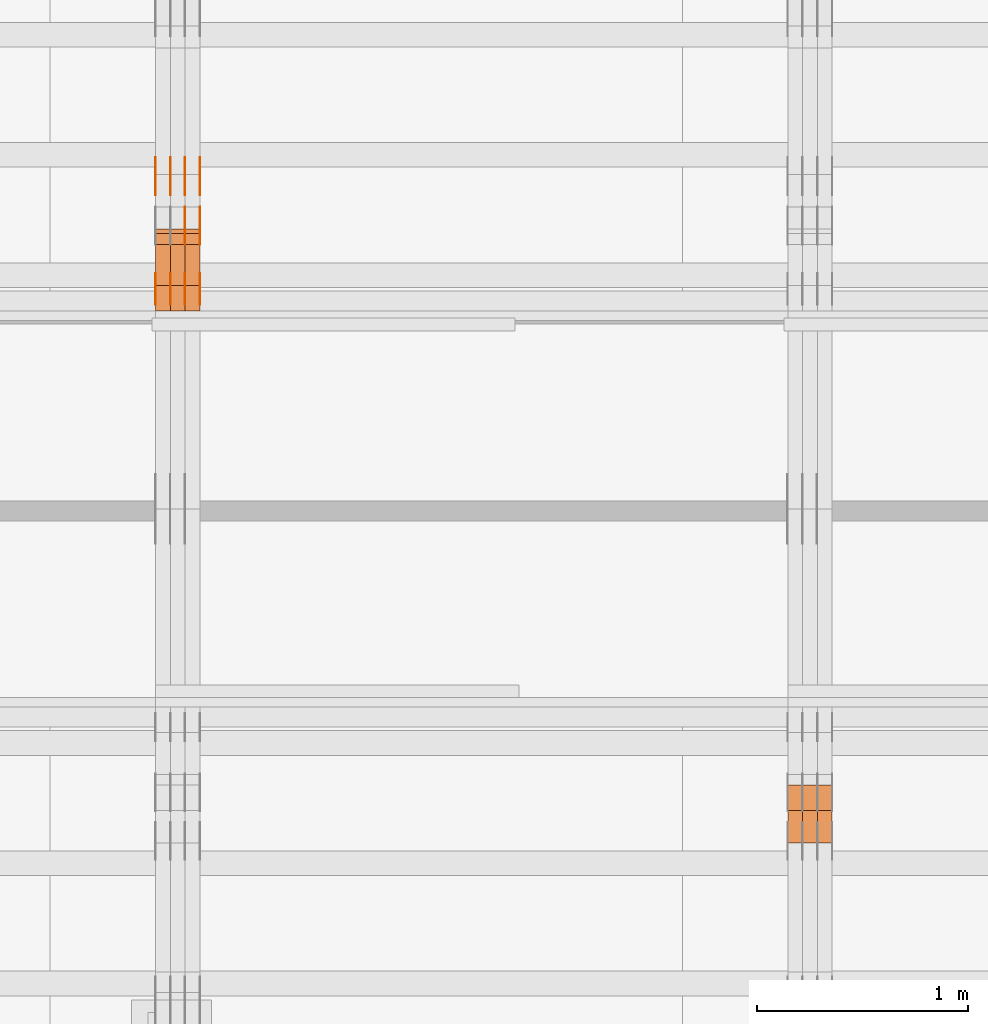
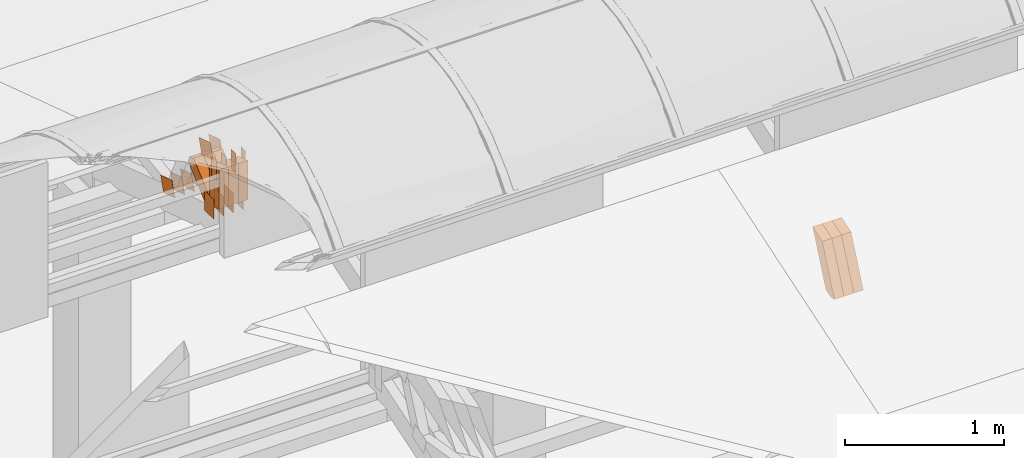
# One storey, part 147 of 385: 30 proxies.
"""IFC2X3 building model written with IfcOpenShell, lengths in millimetres."""

from ifc_helpers import new_model, entity, si_unit, converted_unit, derived_unit, direction, frame, origin, origin_2d_with_axis, place, context, subcontext, project, spatial, polyline, rectangle, outline, extrude, source, transform, mapped, material, type_object, type_shapes, element, save


model = new_model("IFC2X3")

# Units and contexts
model_context = context("Model", 3, precision=0.01, world=origin(), true_north=direction((6.12303176911189e-17, 1.0)))
body_context = subcontext(model_context, "Body", "Model", "MODEL_VIEW")
ifc_project = project(units=[si_unit("LENGTHUNIT", "METRE", prefix="MILLI"), si_unit("AREAUNIT", "SQUARE_METRE"), si_unit("VOLUMEUNIT", "CUBIC_METRE"), converted_unit("PLANEANGLEUNIT", "DEGREE", entity("IfcRatioMeasure", 0.0174532925199433), si_unit("PLANEANGLEUNIT", "RADIAN"), dimensions=[0, 0, 0, 0, 0, 0, 0]), si_unit("MASSUNIT", "GRAM", prefix="KILO"), derived_unit("MASSDENSITYUNIT", [(si_unit("MASSUNIT", "GRAM", prefix="KILO"), 1), (si_unit("LENGTHUNIT", "METRE"), -3)]), si_unit("TIMEUNIT", "SECOND"), si_unit("FREQUENCYUNIT", "HERTZ"), si_unit("THERMODYNAMICTEMPERATUREUNIT", "DEGREE_CELSIUS"), derived_unit("THERMALTRANSMITTANCEUNIT", [(si_unit("MASSUNIT", "GRAM", prefix="KILO"), 1), (si_unit("THERMODYNAMICTEMPERATUREUNIT", "KELVIN"), -1), (si_unit("TIMEUNIT", "SECOND"), -3)]), derived_unit("VOLUMETRICFLOWRATEUNIT", [(si_unit("LENGTHUNIT", "METRE"), 3), (si_unit("TIMEUNIT", "SECOND"), -1)]), si_unit("ELECTRICCURRENTUNIT", "AMPERE"), si_unit("ELECTRICVOLTAGEUNIT", "VOLT"), si_unit("POWERUNIT", "WATT"), si_unit("FORCEUNIT", "NEWTON", prefix="KILO"), si_unit("ILLUMINANCEUNIT", "LUX"), si_unit("LUMINOUSFLUXUNIT", "LUMEN"), si_unit("LUMINOUSINTENSITYUNIT", "CANDELA"), derived_unit("USERDEFINED", [(si_unit("MASSUNIT", "GRAM", prefix="KILO"), -1), (si_unit("LENGTHUNIT", "METRE"), -2), (si_unit("TIMEUNIT", "SECOND"), 3), (si_unit("LUMINOUSFLUXUNIT", "LUMEN"), 1)]), derived_unit("LINEARVELOCITYUNIT", [(si_unit("LENGTHUNIT", "METRE"), 1), (si_unit("TIMEUNIT", "SECOND"), -1)]), si_unit("PRESSUREUNIT", "PASCAL"), derived_unit("USERDEFINED", [(si_unit("LENGTHUNIT", "METRE"), -2), (si_unit("MASSUNIT", "GRAM", prefix="KILO"), 1), (si_unit("TIMEUNIT", "SECOND"), -2)])], contexts=[model_context])

# Site, building, storey
site_placement = place(None, origin())
site = spatial("IfcSite", under=ifc_project, at=site_placement, CompositionType="ELEMENT")
building_placement = place(site_placement, origin())
building = spatial("IfcBuilding", under=site, at=building_placement, CompositionType="ELEMENT")
storey_placement = place(building_placement, origin())
storey = spatial("IfcBuildingStorey", under=building, at=storey_placement, Name="Default", CompositionType="ELEMENT", Elevation=0.0)

# Proxies
ifc_material_1 = material(Name="IfcSurfaceStyle #258636")
building_element_proxy_type_1 = type_object("IfcBuildingElementProxyType", Name="T1-W42 258634", PredefinedType="NOTDEFINED", material=ifc_material_1)
shared_shape_1 = source(origin(), body_context, "Body", "SweptSolid", [
    extrude(outline(polyline([(-284.837590197601, -47.4997543607933), (129.95880168156, -47.4997543607933), (171.972324990451, 0.000162623346093338), (183.717007105413, 47.4996730491203), (-200.810543579822, 47.4996730491203), (-284.837590197601, -47.4997543607933)])), frame((183.717155718752, 47.4999821655365, 0.0), z_axis=(0.0, 0.0, 1.0), x_axis=(-1.0, 0.0, 0.0)), (0.0, 0.0, 1.0), 70.0),
])
type_shapes(building_element_proxy_type_1, [shared_shape_1])
proxy_1_placement = place(building_placement, frame((21385.0, 13135.8834463264, 3404.958483022), z_axis=(-1.0, 0.0, 0.0), x_axis=(0.0, 0.398630596470292, 0.917111578575769)))
element("IfcBuildingElementProxy", 1, at=proxy_1_placement, inside=storey, type_object=building_element_proxy_type_1, material=ifc_material_1, Name="T1-W42", context=body_context, shape_type="MappedRepresentation", body=[
    mapped(shared_shape_1, transform((0.0, 0.0, 0.0), scale=1.0)),
])
ifc_material_2 = material(Name="IfcSurfaceStyle #258570")
building_element_proxy_type_2 = type_object("IfcBuildingElementProxyType", Name="T1-W42 258568", PredefinedType="NOTDEFINED", material=ifc_material_2)
shared_shape_2 = source(origin(), body_context, "Body", "SweptSolid", [
    extrude(outline(polyline([(-284.837590197601, -47.4997543607933), (129.95880168156, -47.4997543607933), (171.972324990451, 0.000162623346093338), (183.717007105413, 47.4996730491203), (-200.810543579822, 47.4996730491203), (-284.837590197601, -47.4997543607933)])), frame((183.717155718752, 47.4999821655365, 0.0), z_axis=(0.0, 0.0, 1.0), x_axis=(-1.0, 0.0, 0.0)), (0.0, 0.0, 1.0), 70.0),
])
type_shapes(building_element_proxy_type_2, [shared_shape_2])
proxy_2_placement = place(building_placement, frame((21315.0, 13135.8834463264, 3404.958483022), z_axis=(-1.0, 0.0, 0.0), x_axis=(0.0, 0.398630596470292, 0.917111578575769)))
element("IfcBuildingElementProxy", 2, at=proxy_2_placement, inside=storey, type_object=building_element_proxy_type_2, material=ifc_material_2, Name="T1-W42", context=body_context, shape_type="MappedRepresentation", body=[
    mapped(shared_shape_2, transform((0.0, 0.0, 0.0), scale=1.0)),
])
ifc_material_3 = material(Name="IfcSurfaceStyle #258504")
building_element_proxy_type_3 = type_object("IfcBuildingElementProxyType", Name="T1-W42 258502", PredefinedType="NOTDEFINED", material=ifc_material_3)
shared_shape_3 = source(origin(), body_context, "Body", "SweptSolid", [
    extrude(outline(polyline([(-284.837590197601, -47.4997543607933), (129.95880168156, -47.4997543607933), (171.972324990451, 0.000162623346093338), (183.717007105413, 47.4996730491203), (-200.810543579822, 47.4996730491203), (-284.837590197601, -47.4997543607933)])), frame((183.717155718752, 47.4999821655365, 0.0), z_axis=(0.0, 0.0, 1.0), x_axis=(-1.0, 0.0, 0.0)), (0.0, 0.0, 1.0), 70.0),
])
type_shapes(building_element_proxy_type_3, [shared_shape_3])
proxy_3_placement = place(building_placement, frame((21245.0, 13135.8834463264, 3404.958483022), z_axis=(-1.0, 0.0, 0.0), x_axis=(0.0, 0.398630596470292, 0.917111578575769)))
element("IfcBuildingElementProxy", 3, at=proxy_3_placement, inside=storey, type_object=building_element_proxy_type_3, material=ifc_material_3, Name="T1-W42", context=body_context, shape_type="MappedRepresentation", body=[
    mapped(shared_shape_3, transform((0.0, 0.0, 0.0), scale=1.0)),
])
ifc_material_4 = material(Name="IfcSurfaceStyle #239810")
building_element_proxy_type_4 = type_object("IfcBuildingElementProxyType", PredefinedType="NOTDEFINED", material=ifc_material_4)
shared_shape_4 = source(origin(), body_context, "Body", "SweptSolid", [
    extrude(rectangle(XDim=150.0, YDim=120.0, at=origin_2d_with_axis()), frame((75.0, 60.0, 0.0), z_axis=(0.0, 0.0, 1.0), x_axis=(-1.0, 0.0, 0.0)), (0.0, 0.0, 1.0), 1.3),
])
type_shapes(building_element_proxy_type_4, [shared_shape_4])
proxy_4_placement = place(building_placement, frame((18386.3, 15840.0, 3652.70166015625), z_axis=(-1.0, 0.0, 0.0), x_axis=(0.0, 0.0, -1.0)))
element("IfcBuildingElementProxy", 4, at=proxy_4_placement, inside=storey, type_object=building_element_proxy_type_4, material=ifc_material_4, context=body_context, shape_type="MappedRepresentation", body=[
    mapped(shared_shape_4, transform((0.0, 0.0, 0.0), scale=1.0)),
])
ifc_material_5 = material(Name="IfcSurfaceStyle #239753")
building_element_proxy_type_5 = type_object("IfcBuildingElementProxyType", PredefinedType="NOTDEFINED", material=ifc_material_5)
shared_shape_5 = source(origin(), body_context, "Body", "SweptSolid", [
    extrude(rectangle(XDim=150.0, YDim=120.0, at=origin_2d_with_axis()), frame((75.0, 60.0, 0.0), z_axis=(0.0, 0.0, 1.0), x_axis=(-1.0, 0.0, 0.0)), (0.0, 0.0, 1.0), 1.3),
])
type_shapes(building_element_proxy_type_5, [shared_shape_5])
proxy_5_placement = place(building_placement, frame((18315.0, 15840.0, 3652.70166015625), z_axis=(-1.0, 0.0, 0.0), x_axis=(0.0, 0.0, -1.0)))
element("IfcBuildingElementProxy", 5, at=proxy_5_placement, inside=storey, type_object=building_element_proxy_type_5, material=ifc_material_5, context=body_context, shape_type="MappedRepresentation", body=[
    mapped(shared_shape_5, transform((0.0, 0.0, 0.0), scale=1.0)),
])
ifc_material_6 = material(Name="IfcSurfaceStyle #239696")
building_element_proxy_type_6 = type_object("IfcBuildingElementProxyType", PredefinedType="NOTDEFINED", material=ifc_material_6)
shared_shape_6 = source(origin(), body_context, "Body", "SweptSolid", [
    extrude(rectangle(XDim=150.0, YDim=120.0, at=origin_2d_with_axis()), frame((75.0, 60.0, 0.0), z_axis=(0.0, 0.0, 1.0), x_axis=(-1.0, 0.0, 0.0)), (0.0, 0.0, 1.0), 1.3),
])
type_shapes(building_element_proxy_type_6, [shared_shape_6])
proxy_6_placement = place(building_placement, frame((18316.3, 15840.0, 3652.70166015625), z_axis=(-1.0, 0.0, 0.0), x_axis=(0.0, 0.0, -1.0)))
element("IfcBuildingElementProxy", 6, at=proxy_6_placement, inside=storey, type_object=building_element_proxy_type_6, material=ifc_material_6, context=body_context, shape_type="MappedRepresentation", body=[
    mapped(shared_shape_6, transform((0.0, 0.0, 0.0), scale=1.0)),
])
ifc_material_7 = material(Name="IfcSurfaceStyle #239639")
building_element_proxy_type_7 = type_object("IfcBuildingElementProxyType", PredefinedType="NOTDEFINED", material=ifc_material_7)
shared_shape_7 = source(origin(), body_context, "Body", "SweptSolid", [
    extrude(rectangle(XDim=150.0, YDim=120.0, at=origin_2d_with_axis()), frame((75.0, 60.0, 0.0), z_axis=(0.0, 0.0, 1.0), x_axis=(-1.0, 0.0, 0.0)), (0.0, 0.0, 1.0), 1.29999999999999),
])
type_shapes(building_element_proxy_type_7, [shared_shape_7])
proxy_7_placement = place(building_placement, frame((18245.0, 15840.0, 3652.70166015625), z_axis=(-1.0, 0.0, 0.0), x_axis=(0.0, 0.0, -1.0)))
element("IfcBuildingElementProxy", 7, at=proxy_7_placement, inside=storey, type_object=building_element_proxy_type_7, material=ifc_material_7, context=body_context, shape_type="MappedRepresentation", body=[
    mapped(shared_shape_7, transform((0.0, 0.0, 0.0), scale=1.0)),
])
ifc_material_8 = material(Name="IfcSurfaceStyle #239582")
building_element_proxy_type_8 = type_object("IfcBuildingElementProxyType", PredefinedType="NOTDEFINED", material=ifc_material_8)
shared_shape_8 = source(origin(), body_context, "Body", "SweptSolid", [
    extrude(rectangle(XDim=150.0, YDim=120.0, at=origin_2d_with_axis()), frame((75.0, 60.0, 0.0), z_axis=(0.0, 0.0, 1.0), x_axis=(-1.0, 0.0, 0.0)), (0.0, 0.0, 1.0), 1.29999999999999),
])
type_shapes(building_element_proxy_type_8, [shared_shape_8])
proxy_8_placement = place(building_placement, frame((18246.3, 15840.0, 3652.70166015625), z_axis=(-1.0, 0.0, 0.0), x_axis=(0.0, 0.0, -1.0)))
element("IfcBuildingElementProxy", 8, at=proxy_8_placement, inside=storey, type_object=building_element_proxy_type_8, material=ifc_material_8, context=body_context, shape_type="MappedRepresentation", body=[
    mapped(shared_shape_8, transform((0.0, 0.0, 0.0), scale=1.0)),
])
ifc_material_9 = material(Name="IfcSurfaceStyle #239525")
building_element_proxy_type_9 = type_object("IfcBuildingElementProxyType", PredefinedType="NOTDEFINED", material=ifc_material_9)
shared_shape_9 = source(origin(), body_context, "Body", "SweptSolid", [
    extrude(rectangle(XDim=150.0, YDim=120.0, at=origin_2d_with_axis()), frame((75.0, 60.0, 0.0), z_axis=(0.0, 0.0, 1.0), x_axis=(-1.0, 0.0, 0.0)), (0.0, 0.0, 1.0), 1.29999999999999),
])
type_shapes(building_element_proxy_type_9, [shared_shape_9])
proxy_9_placement = place(building_placement, frame((18175.0, 15840.0, 3652.70166015625), z_axis=(-1.0, 0.0, 0.0), x_axis=(0.0, 0.0, -1.0)))
element("IfcBuildingElementProxy", 9, at=proxy_9_placement, inside=storey, type_object=building_element_proxy_type_9, material=ifc_material_9, context=body_context, shape_type="MappedRepresentation", body=[
    mapped(shared_shape_9, transform((0.0, 0.0, 0.0), scale=1.0)),
])
ifc_material_10 = material(Name="IfcSurfaceStyle #239468")
building_element_proxy_type_10 = type_object("IfcBuildingElementProxyType", PredefinedType="NOTDEFINED", material=ifc_material_10)
shared_shape_10 = source(origin(), body_context, "Body", "SweptSolid", [
    extrude(outline(polyline([(-74.9998605591118, -59.9999264677601), (74.9998754286171, -59.9999264677601), (74.9998605591118, 59.9999264677602), (-74.9998754286171, 59.9999264677602), (-74.9998605591118, -59.9999264677601)])), frame((74.9998754286171, 60.0000503992849, 0.0), z_axis=(0.0, 0.0, 1.0), x_axis=(-1.0, 0.0, 0.0)), (0.0, 0.0, 1.0), 1.3),
])
type_shapes(building_element_proxy_type_10, [shared_shape_10])
proxy_10_placement = place(building_placement, frame((18386.3, 16352.8320303235, 3323.23212676408), z_axis=(-1.0, 0.0, 0.0), x_axis=(0.0, -0.951056516295124, 0.309016994375039)))
element("IfcBuildingElementProxy", 10, at=proxy_10_placement, inside=storey, type_object=building_element_proxy_type_10, material=ifc_material_10, context=body_context, shape_type="MappedRepresentation", body=[
    mapped(shared_shape_10, transform((0.0, 0.0, 0.0), scale=1.0)),
])
ifc_material_11 = material(Name="IfcSurfaceStyle #239411")
building_element_proxy_type_11 = type_object("IfcBuildingElementProxyType", PredefinedType="NOTDEFINED", material=ifc_material_11)
shared_shape_11 = source(origin(), body_context, "Body", "SweptSolid", [
    extrude(outline(polyline([(-74.9998605591118, -59.9999264677601), (74.9998754286171, -59.9999264677601), (74.9998605591118, 59.9999264677602), (-74.9998754286171, 59.9999264677602), (-74.9998605591118, -59.9999264677601)])), frame((74.9998754286171, 60.0000503992849, 0.0), z_axis=(0.0, 0.0, 1.0), x_axis=(-1.0, 0.0, 0.0)), (0.0, 0.0, 1.0), 1.3),
])
type_shapes(building_element_proxy_type_11, [shared_shape_11])
proxy_11_placement = place(building_placement, frame((18315.0, 16352.8320303235, 3323.23212676408), z_axis=(-1.0, 0.0, 0.0), x_axis=(0.0, -0.951056516295124, 0.309016994375039)))
element("IfcBuildingElementProxy", 11, at=proxy_11_placement, inside=storey, type_object=building_element_proxy_type_11, material=ifc_material_11, context=body_context, shape_type="MappedRepresentation", body=[
    mapped(shared_shape_11, transform((0.0, 0.0, 0.0), scale=1.0)),
])
ifc_material_12 = material(Name="IfcSurfaceStyle #239354")
building_element_proxy_type_12 = type_object("IfcBuildingElementProxyType", PredefinedType="NOTDEFINED", material=ifc_material_12)
shared_shape_12 = source(origin(), body_context, "Body", "SweptSolid", [
    extrude(outline(polyline([(-74.9998605591118, -59.9999264677601), (74.9998754286171, -59.9999264677601), (74.9998605591118, 59.9999264677602), (-74.9998754286171, 59.9999264677602), (-74.9998605591118, -59.9999264677601)])), frame((74.9998754286171, 60.0000503992849, 0.0), z_axis=(0.0, 0.0, 1.0), x_axis=(-1.0, 0.0, 0.0)), (0.0, 0.0, 1.0), 1.3),
])
type_shapes(building_element_proxy_type_12, [shared_shape_12])
proxy_12_placement = place(building_placement, frame((18316.3, 16352.8320303235, 3323.23212676408), z_axis=(-1.0, 0.0, 0.0), x_axis=(0.0, -0.951056516295124, 0.309016994375039)))
element("IfcBuildingElementProxy", 12, at=proxy_12_placement, inside=storey, type_object=building_element_proxy_type_12, material=ifc_material_12, context=body_context, shape_type="MappedRepresentation", body=[
    mapped(shared_shape_12, transform((0.0, 0.0, 0.0), scale=1.0)),
])
ifc_material_13 = material(Name="IfcSurfaceStyle #239297")
building_element_proxy_type_13 = type_object("IfcBuildingElementProxyType", PredefinedType="NOTDEFINED", material=ifc_material_13)
shared_shape_13 = source(origin(), body_context, "Body", "SweptSolid", [
    extrude(outline(polyline([(-74.9998605591118, -59.9999264677601), (74.9998754286171, -59.9999264677601), (74.9998605591118, 59.9999264677602), (-74.9998754286171, 59.9999264677602), (-74.9998605591118, -59.9999264677601)])), frame((74.9998754286171, 60.0000503992849, 0.0), z_axis=(0.0, 0.0, 1.0), x_axis=(-1.0, 0.0, 0.0)), (0.0, 0.0, 1.0), 1.29999999999999),
])
type_shapes(building_element_proxy_type_13, [shared_shape_13])
proxy_13_placement = place(building_placement, frame((18245.0, 16352.8320303235, 3323.23212676408), z_axis=(-1.0, 0.0, 0.0), x_axis=(0.0, -0.951056516295124, 0.309016994375039)))
element("IfcBuildingElementProxy", 13, at=proxy_13_placement, inside=storey, type_object=building_element_proxy_type_13, material=ifc_material_13, context=body_context, shape_type="MappedRepresentation", body=[
    mapped(shared_shape_13, transform((0.0, 0.0, 0.0), scale=1.0)),
])
ifc_material_14 = material(Name="IfcSurfaceStyle #239240")
building_element_proxy_type_14 = type_object("IfcBuildingElementProxyType", PredefinedType="NOTDEFINED", material=ifc_material_14)
shared_shape_14 = source(origin(), body_context, "Body", "SweptSolid", [
    extrude(outline(polyline([(-74.9998605591118, -59.9999264677601), (74.9998754286171, -59.9999264677601), (74.9998605591118, 59.9999264677602), (-74.9998754286171, 59.9999264677602), (-74.9998605591118, -59.9999264677601)])), frame((74.9998754286171, 60.0000503992849, 0.0), z_axis=(0.0, 0.0, 1.0), x_axis=(-1.0, 0.0, 0.0)), (0.0, 0.0, 1.0), 1.29999999999999),
])
type_shapes(building_element_proxy_type_14, [shared_shape_14])
proxy_14_placement = place(building_placement, frame((18246.3, 16352.8320303235, 3323.23212676408), z_axis=(-1.0, 0.0, 0.0), x_axis=(0.0, -0.951056516295124, 0.309016994375039)))
element("IfcBuildingElementProxy", 14, at=proxy_14_placement, inside=storey, type_object=building_element_proxy_type_14, material=ifc_material_14, context=body_context, shape_type="MappedRepresentation", body=[
    mapped(shared_shape_14, transform((0.0, 0.0, 0.0), scale=1.0)),
])
ifc_material_15 = material(Name="IfcSurfaceStyle #239183")
building_element_proxy_type_15 = type_object("IfcBuildingElementProxyType", PredefinedType="NOTDEFINED", material=ifc_material_15)
shared_shape_15 = source(origin(), body_context, "Body", "SweptSolid", [
    extrude(outline(polyline([(-74.9998605591118, -59.9999264677601), (74.9998754286171, -59.9999264677601), (74.9998605591118, 59.9999264677602), (-74.9998754286171, 59.9999264677602), (-74.9998605591118, -59.9999264677601)])), frame((74.9998754286171, 60.0000503992849, 0.0), z_axis=(0.0, 0.0, 1.0), x_axis=(-1.0, 0.0, 0.0)), (0.0, 0.0, 1.0), 1.29999999999999),
])
type_shapes(building_element_proxy_type_15, [shared_shape_15])
proxy_15_placement = place(building_placement, frame((18175.0, 16352.8320303235, 3323.23212676408), z_axis=(-1.0, 0.0, 0.0), x_axis=(0.0, -0.951056516295124, 0.309016994375039)))
element("IfcBuildingElementProxy", 15, at=proxy_15_placement, inside=storey, type_object=building_element_proxy_type_15, material=ifc_material_15, context=body_context, shape_type="MappedRepresentation", body=[
    mapped(shared_shape_15, transform((0.0, 0.0, 0.0), scale=1.0)),
])
ifc_material_16 = material(Name="IfcSurfaceStyle #235022")
building_element_proxy_type_16 = type_object("IfcBuildingElementProxyType", PredefinedType="NOTDEFINED", material=ifc_material_16)
shared_shape_16 = source(origin(), body_context, "Body", "SweptSolid", [
    extrude(outline(polyline([(-75.0003249421702, -60.0000773549573), (75.0003398116874, -60.0000773549573), (75.0003249421711, 60.0000773549573), (-75.0003398116883, 60.0000773549573), (-75.0003249421702, -60.0000773549573)])), frame((75.0003398116874, 60.0000773549573, 0.0), z_axis=(0.0, 0.0, 1.0), x_axis=(-1.0, 0.0, 0.0)), (0.0, 0.0, 1.0), 1.3),
])
type_shapes(building_element_proxy_type_16, [shared_shape_16])
proxy_16_placement = place(building_placement, frame((18386.3, 16117.0849050545, 3705.49074668796), z_axis=(-1.0, 0.0, 0.0), x_axis=(0.0, -0.951056516295154, 0.309016994374948)))
element("IfcBuildingElementProxy", 16, at=proxy_16_placement, inside=storey, type_object=building_element_proxy_type_16, material=ifc_material_16, context=body_context, shape_type="MappedRepresentation", body=[
    mapped(shared_shape_16, transform((0.0, 0.0, 0.0), scale=1.0)),
])
ifc_material_17 = material(Name="IfcSurfaceStyle #234965")
building_element_proxy_type_17 = type_object("IfcBuildingElementProxyType", PredefinedType="NOTDEFINED", material=ifc_material_17)
shared_shape_17 = source(origin(), body_context, "Body", "SweptSolid", [
    extrude(outline(polyline([(-75.0003249421702, -60.0000773549573), (75.0003398116874, -60.0000773549573), (75.0003249421711, 60.0000773549573), (-75.0003398116883, 60.0000773549573), (-75.0003249421702, -60.0000773549573)])), frame((75.0003398116874, 60.0000773549573, 0.0), z_axis=(0.0, 0.0, 1.0), x_axis=(-1.0, 0.0, 0.0)), (0.0, 0.0, 1.0), 1.3),
])
type_shapes(building_element_proxy_type_17, [shared_shape_17])
proxy_17_placement = place(building_placement, frame((18315.0, 16117.0849050545, 3705.49074668796), z_axis=(-1.0, 0.0, 0.0), x_axis=(0.0, -0.951056516295154, 0.309016994374948)))
element("IfcBuildingElementProxy", 17, at=proxy_17_placement, inside=storey, type_object=building_element_proxy_type_17, material=ifc_material_17, context=body_context, shape_type="MappedRepresentation", body=[
    mapped(shared_shape_17, transform((0.0, 0.0, 0.0), scale=1.0)),
])
ifc_material_18 = material(Name="IfcSurfaceStyle #234908")
building_element_proxy_type_18 = type_object("IfcBuildingElementProxyType", PredefinedType="NOTDEFINED", material=ifc_material_18)
shared_shape_18 = source(origin(), body_context, "Body", "SweptSolid", [
    extrude(outline(polyline([(-75.0003249421702, -60.0000773549573), (75.0003398116874, -60.0000773549573), (75.0003249421711, 60.0000773549573), (-75.0003398116883, 60.0000773549573), (-75.0003249421702, -60.0000773549573)])), frame((75.0003398116874, 60.0000773549573, 0.0), z_axis=(0.0, 0.0, 1.0), x_axis=(-1.0, 0.0, 0.0)), (0.0, 0.0, 1.0), 1.3),
])
type_shapes(building_element_proxy_type_18, [shared_shape_18])
proxy_18_placement = place(building_placement, frame((18316.3, 16117.0849050545, 3705.49074668796), z_axis=(-1.0, 0.0, 0.0), x_axis=(0.0, -0.951056516295154, 0.309016994374948)))
element("IfcBuildingElementProxy", 18, at=proxy_18_placement, inside=storey, type_object=building_element_proxy_type_18, material=ifc_material_18, context=body_context, shape_type="MappedRepresentation", body=[
    mapped(shared_shape_18, transform((0.0, 0.0, 0.0), scale=1.0)),
])
ifc_material_19 = material(Name="IfcSurfaceStyle #234338")
building_element_proxy_type_19 = type_object("IfcBuildingElementProxyType", PredefinedType="NOTDEFINED", material=ifc_material_19)
shared_shape_19 = source(origin(), body_context, "Body", "SweptSolid", [
    extrude(rectangle(XDim=150.0, YDim=60.0, at=origin_2d_with_axis()), frame((75.0000705696311, 30.0, 0.0), z_axis=(0.0, 0.0, 1.0), x_axis=(-1.0, 0.0, 0.0)), (0.0, 0.0, 1.0), 1.3),
])
type_shapes(building_element_proxy_type_19, [shared_shape_19])
proxy_19_placement = place(building_placement, frame((18386.3, 15750.0, 3972.59919166338), z_axis=(-1.0, 0.0, 0.0), x_axis=(0.0, 0.0, -1.0)))
element("IfcBuildingElementProxy", 19, at=proxy_19_placement, inside=storey, type_object=building_element_proxy_type_19, material=ifc_material_19, context=body_context, shape_type="MappedRepresentation", body=[
    mapped(shared_shape_19, transform((0.0, 0.0, 0.0), scale=1.0)),
])
ifc_material_20 = material(Name="IfcSurfaceStyle #234281")
building_element_proxy_type_20 = type_object("IfcBuildingElementProxyType", PredefinedType="NOTDEFINED", material=ifc_material_20)
shared_shape_20 = source(origin(), body_context, "Body", "SweptSolid", [
    extrude(rectangle(XDim=150.0, YDim=60.0, at=origin_2d_with_axis()), frame((75.0000705696311, 30.0, 0.0), z_axis=(0.0, 0.0, 1.0), x_axis=(-1.0, 0.0, 0.0)), (0.0, 0.0, 1.0), 1.3),
])
type_shapes(building_element_proxy_type_20, [shared_shape_20])
proxy_20_placement = place(building_placement, frame((18315.0, 15750.0, 3972.59919166338), z_axis=(-1.0, 0.0, 0.0), x_axis=(0.0, 0.0, -1.0)))
element("IfcBuildingElementProxy", 20, at=proxy_20_placement, inside=storey, type_object=building_element_proxy_type_20, material=ifc_material_20, context=body_context, shape_type="MappedRepresentation", body=[
    mapped(shared_shape_20, transform((0.0, 0.0, 0.0), scale=1.0)),
])
ifc_material_21 = material(Name="IfcSurfaceStyle #234224")
building_element_proxy_type_21 = type_object("IfcBuildingElementProxyType", PredefinedType="NOTDEFINED", material=ifc_material_21)
shared_shape_21 = source(origin(), body_context, "Body", "SweptSolid", [
    extrude(rectangle(XDim=150.0, YDim=60.0, at=origin_2d_with_axis()), frame((75.0000705696311, 30.0, 0.0), z_axis=(0.0, 0.0, 1.0), x_axis=(-1.0, 0.0, 0.0)), (0.0, 0.0, 1.0), 1.3),
])
type_shapes(building_element_proxy_type_21, [shared_shape_21])
proxy_21_placement = place(building_placement, frame((18316.3, 15750.0, 3972.59919166338), z_axis=(-1.0, 0.0, 0.0), x_axis=(0.0, 0.0, -1.0)))
element("IfcBuildingElementProxy", 21, at=proxy_21_placement, inside=storey, type_object=building_element_proxy_type_21, material=ifc_material_21, context=body_context, shape_type="MappedRepresentation", body=[
    mapped(shared_shape_21, transform((0.0, 0.0, 0.0), scale=1.0)),
])
ifc_material_22 = material(Name="IfcSurfaceStyle #234167")
building_element_proxy_type_22 = type_object("IfcBuildingElementProxyType", PredefinedType="NOTDEFINED", material=ifc_material_22)
shared_shape_22 = source(origin(), body_context, "Body", "SweptSolid", [
    extrude(rectangle(XDim=150.0, YDim=60.0, at=origin_2d_with_axis()), frame((75.0000705696311, 30.0, 0.0), z_axis=(0.0, 0.0, 1.0), x_axis=(-1.0, 0.0, 0.0)), (0.0, 0.0, 1.0), 1.29999999999999),
])
type_shapes(building_element_proxy_type_22, [shared_shape_22])
proxy_22_placement = place(building_placement, frame((18245.0, 15750.0, 3972.59919166338), z_axis=(-1.0, 0.0, 0.0), x_axis=(0.0, 0.0, -1.0)))
element("IfcBuildingElementProxy", 22, at=proxy_22_placement, inside=storey, type_object=building_element_proxy_type_22, material=ifc_material_22, context=body_context, shape_type="MappedRepresentation", body=[
    mapped(shared_shape_22, transform((0.0, 0.0, 0.0), scale=1.0)),
])
ifc_material_23 = material(Name="IfcSurfaceStyle #234110")
building_element_proxy_type_23 = type_object("IfcBuildingElementProxyType", PredefinedType="NOTDEFINED", material=ifc_material_23)
shared_shape_23 = source(origin(), body_context, "Body", "SweptSolid", [
    extrude(rectangle(XDim=150.0, YDim=60.0, at=origin_2d_with_axis()), frame((75.0000705696311, 30.0, 0.0), z_axis=(0.0, 0.0, 1.0), x_axis=(-1.0, 0.0, 0.0)), (0.0, 0.0, 1.0), 1.29999999999999),
])
type_shapes(building_element_proxy_type_23, [shared_shape_23])
proxy_23_placement = place(building_placement, frame((18246.3, 15750.0, 3972.59919166338), z_axis=(-1.0, 0.0, 0.0), x_axis=(0.0, 0.0, -1.0)))
element("IfcBuildingElementProxy", 23, at=proxy_23_placement, inside=storey, type_object=building_element_proxy_type_23, material=ifc_material_23, context=body_context, shape_type="MappedRepresentation", body=[
    mapped(shared_shape_23, transform((0.0, 0.0, 0.0), scale=1.0)),
])
ifc_material_24 = material(Name="IfcSurfaceStyle #234053")
building_element_proxy_type_24 = type_object("IfcBuildingElementProxyType", PredefinedType="NOTDEFINED", material=ifc_material_24)
shared_shape_24 = source(origin(), body_context, "Body", "SweptSolid", [
    extrude(rectangle(XDim=150.0, YDim=60.0, at=origin_2d_with_axis()), frame((75.0000705696311, 30.0, 0.0), z_axis=(0.0, 0.0, 1.0), x_axis=(-1.0, 0.0, 0.0)), (0.0, 0.0, 1.0), 1.29999999999999),
])
type_shapes(building_element_proxy_type_24, [shared_shape_24])
proxy_24_placement = place(building_placement, frame((18175.0, 15750.0, 3972.59919166338), z_axis=(-1.0, 0.0, 0.0), x_axis=(0.0, 0.0, -1.0)))
element("IfcBuildingElementProxy", 24, at=proxy_24_placement, inside=storey, type_object=building_element_proxy_type_24, material=ifc_material_24, context=body_context, shape_type="MappedRepresentation", body=[
    mapped(shared_shape_24, transform((0.0, 0.0, 0.0), scale=1.0)),
])
ifc_material_25 = material(Name="IfcSurfaceStyle #224969")
building_element_proxy_type_25 = type_object("IfcBuildingElementProxyType", Name="T1-W50 224967", PredefinedType="NOTDEFINED", material=ifc_material_25)
shared_shape_25 = source(origin(), body_context, "Body", "SweptSolid", [
    extrude(outline(polyline([(-128.56619634284, -47.4999385885712), (133.151257249084, -47.4999385885712), (161.172800006526, -0.000129729183733609), (147.291467726413, 47.500068317755), (-142.513973767368, 47.500068317755), (-170.535354871815, -0.000129729183754689), (-128.56619634284, -47.4999385885712)])), frame((161.17310141218, 47.5001898716564, 0.0), z_axis=(0.0, 0.0, 1.0), x_axis=(-1.0, 0.0, 0.0)), (0.0, 0.0, 1.0), 70.0),
])
type_shapes(building_element_proxy_type_25, [shared_shape_25])
proxy_25_placement = place(building_placement, frame((18385.0, 16060.0297689714, 3761.73994820667), z_axis=(-1.0, 0.0, 0.0), x_axis=(0.0, -0.749388407538668, -0.662130662820156)))
element("IfcBuildingElementProxy", 25, at=proxy_25_placement, inside=storey, type_object=building_element_proxy_type_25, material=ifc_material_25, Name="T1-W50", context=body_context, shape_type="MappedRepresentation", body=[
    mapped(shared_shape_25, transform((0.0, 0.0, 0.0), scale=1.0)),
])
ifc_material_26 = material(Name="IfcSurfaceStyle #224894")
building_element_proxy_type_26 = type_object("IfcBuildingElementProxyType", Name="T1-W50 224892", PredefinedType="NOTDEFINED", material=ifc_material_26)
shared_shape_26 = source(origin(), body_context, "Body", "SweptSolid", [
    extrude(outline(polyline([(-128.56619634284, -47.4999385885712), (133.151257249084, -47.4999385885712), (161.172800006526, -0.000129729183733609), (147.291467726413, 47.500068317755), (-142.513973767368, 47.500068317755), (-170.535354871815, -0.000129729183754689), (-128.56619634284, -47.4999385885712)])), frame((161.17310141218, 47.5001898716564, 0.0), z_axis=(0.0, 0.0, 1.0), x_axis=(-1.0, 0.0, 0.0)), (0.0, 0.0, 1.0), 70.0),
])
type_shapes(building_element_proxy_type_26, [shared_shape_26])
proxy_26_placement = place(building_placement, frame((18315.0, 16060.0297689714, 3761.73994820667), z_axis=(-1.0, 0.0, 0.0), x_axis=(0.0, -0.749388407538668, -0.662130662820156)))
element("IfcBuildingElementProxy", 26, at=proxy_26_placement, inside=storey, type_object=building_element_proxy_type_26, material=ifc_material_26, Name="T1-W50", context=body_context, shape_type="MappedRepresentation", body=[
    mapped(shared_shape_26, transform((0.0, 0.0, 0.0), scale=1.0)),
])
ifc_material_27 = material(Name="IfcSurfaceStyle #224819")
building_element_proxy_type_27 = type_object("IfcBuildingElementProxyType", Name="T1-W50 224817", PredefinedType="NOTDEFINED", material=ifc_material_27)
shared_shape_27 = source(origin(), body_context, "Body", "SweptSolid", [
    extrude(outline(polyline([(-128.56619634284, -47.4999385885712), (133.151257249084, -47.4999385885712), (161.172800006526, -0.000129729183733609), (147.291467726413, 47.500068317755), (-142.513973767368, 47.500068317755), (-170.535354871815, -0.000129729183754689), (-128.56619634284, -47.4999385885712)])), frame((161.17310141218, 47.5001898716564, 0.0), z_axis=(0.0, 0.0, 1.0), x_axis=(-1.0, 0.0, 0.0)), (0.0, 0.0, 1.0), 70.0),
])
type_shapes(building_element_proxy_type_27, [shared_shape_27])
proxy_27_placement = place(building_placement, frame((18245.0, 16060.0297689714, 3761.73994820667), z_axis=(-1.0, 0.0, 0.0), x_axis=(0.0, -0.749388407538668, -0.662130662820156)))
element("IfcBuildingElementProxy", 27, at=proxy_27_placement, inside=storey, type_object=building_element_proxy_type_27, material=ifc_material_27, Name="T1-W50", context=body_context, shape_type="MappedRepresentation", body=[
    mapped(shared_shape_27, transform((0.0, 0.0, 0.0), scale=1.0)),
])
ifc_material_28 = material(Name="IfcSurfaceStyle #224573")
building_element_proxy_type_28 = type_object("IfcBuildingElementProxyType", Name="T1-W2 224571", PredefinedType="NOTDEFINED", material=ifc_material_28)
shared_shape_28 = source(origin(), body_context, "Body", "SweptSolid", [
    extrude(outline(polyline([(-130.705993652344, -60.0), (169.696350097656, -60.0), (130.706115722656, 60.0), (-169.696472167969, 60.0), (-130.705993652344, -60.0)])), frame((169.696429629256, 60.0, 0.0), z_axis=(0.0, 0.0, 1.0), x_axis=(-1.0, 0.0, 0.0)), (0.0, 0.0, 1.0), 70.0),
])
type_shapes(building_element_proxy_type_28, [shared_shape_28])
proxy_28_placement = place(building_placement, frame((18385.0, 15660.0, 3577.70158062465), z_axis=(-1.0, 0.0, 0.0), x_axis=(0.0, 0.0, 1.0)))
element("IfcBuildingElementProxy", 28, at=proxy_28_placement, inside=storey, type_object=building_element_proxy_type_28, material=ifc_material_28, Name="T1-W2", context=body_context, shape_type="MappedRepresentation", body=[
    mapped(shared_shape_28, transform((0.0, 0.0, 0.0), scale=1.0)),
])
ifc_material_29 = material(Name="IfcSurfaceStyle #224516")
building_element_proxy_type_29 = type_object("IfcBuildingElementProxyType", Name="T1-W2 224514", PredefinedType="NOTDEFINED", material=ifc_material_29)
shared_shape_29 = source(origin(), body_context, "Body", "SweptSolid", [
    extrude(outline(polyline([(-130.705993652344, -60.0), (169.696350097656, -60.0), (130.706115722656, 60.0), (-169.696472167969, 60.0), (-130.705993652344, -60.0)])), frame((169.696429629256, 60.0, 0.0), z_axis=(0.0, 0.0, 1.0), x_axis=(-1.0, 0.0, 0.0)), (0.0, 0.0, 1.0), 70.0),
])
type_shapes(building_element_proxy_type_29, [shared_shape_29])
proxy_29_placement = place(building_placement, frame((18315.0, 15660.0, 3577.70158062465), z_axis=(-1.0, 0.0, 0.0), x_axis=(0.0, 0.0, 1.0)))
element("IfcBuildingElementProxy", 29, at=proxy_29_placement, inside=storey, type_object=building_element_proxy_type_29, material=ifc_material_29, Name="T1-W2", context=body_context, shape_type="MappedRepresentation", body=[
    mapped(shared_shape_29, transform((0.0, 0.0, 0.0), scale=1.0)),
])
ifc_material_30 = material(Name="IfcSurfaceStyle #224459")
building_element_proxy_type_30 = type_object("IfcBuildingElementProxyType", Name="T1-W2 224457", PredefinedType="NOTDEFINED", material=ifc_material_30)
shared_shape_30 = source(origin(), body_context, "Body", "SweptSolid", [
    extrude(outline(polyline([(-130.705993652344, -60.0), (169.696350097656, -60.0), (130.706115722656, 60.0), (-169.696472167969, 60.0), (-130.705993652344, -60.0)])), frame((169.696429629256, 60.0, 0.0), z_axis=(0.0, 0.0, 1.0), x_axis=(-1.0, 0.0, 0.0)), (0.0, 0.0, 1.0), 70.0),
])
type_shapes(building_element_proxy_type_30, [shared_shape_30])
proxy_30_placement = place(building_placement, frame((18245.0, 15660.0, 3577.70158062465), z_axis=(-1.0, 0.0, 0.0), x_axis=(0.0, 0.0, 1.0)))
element("IfcBuildingElementProxy", 30, at=proxy_30_placement, inside=storey, type_object=building_element_proxy_type_30, material=ifc_material_30, Name="T1-W2", context=body_context, shape_type="MappedRepresentation", body=[
    mapped(shared_shape_30, transform((0.0, 0.0, 0.0), scale=1.0)),
])

save(model, "model.ifc")
